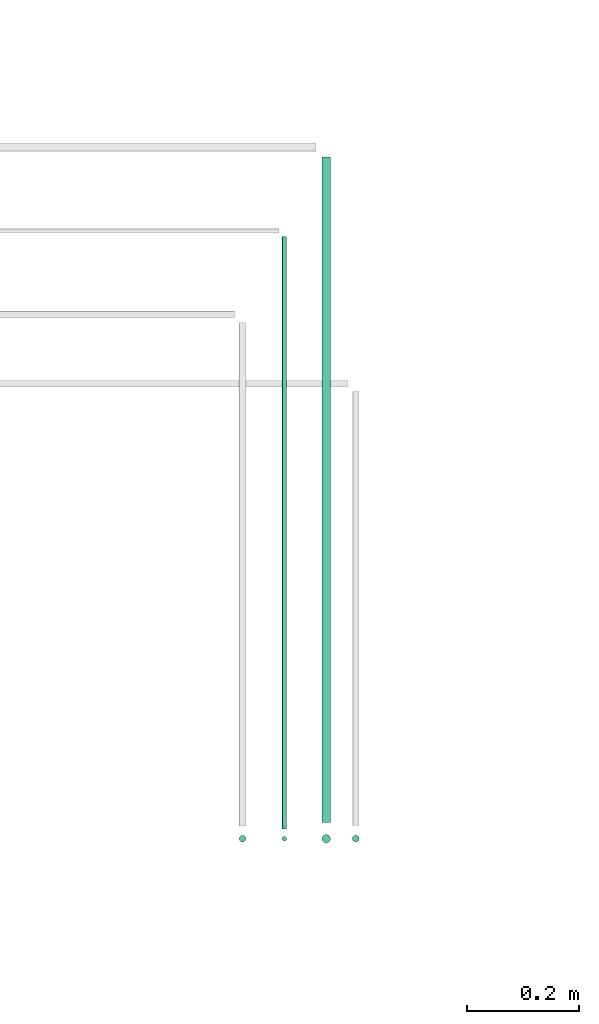
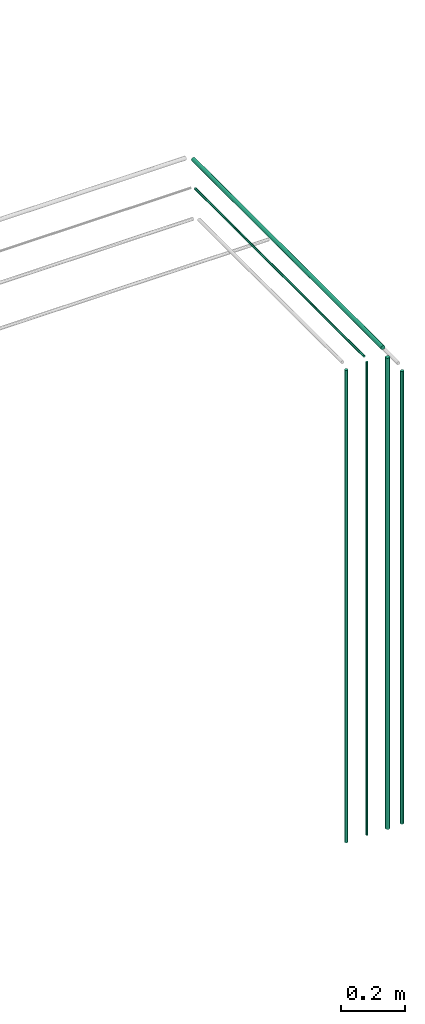
# One storey, part 23 of 65: 6 flow segments.
"""IFC2X3 building model written with IfcOpenShell, lengths in millimetres."""

from ifc_helpers import new_model, entity, si_unit, converted_unit, derived_unit, direction, frame, frame_2d, origin, origin_2d_with_axis, place, context, subcontext, project, spatial, circle, extrude, type_object, element, save


model = new_model("IFC2X3")

# Units and contexts
model_context = context("Model", 3, precision=0.01, world=origin(), true_north=direction((6.12303176911189e-17, 1.0)))
body_context = subcontext(model_context, "Body", "Model", "MODEL_VIEW")
ifc_project = project(units=[si_unit("LENGTHUNIT", "METRE", prefix="MILLI"), si_unit("AREAUNIT", "SQUARE_METRE"), si_unit("VOLUMEUNIT", "CUBIC_METRE"), converted_unit("PLANEANGLEUNIT", "DEGREE", entity("IfcRatioMeasure", 0.0174532925199433), si_unit("PLANEANGLEUNIT", "RADIAN"), dimensions=[0, 0, 0, 0, 0, 0, 0]), si_unit("MASSUNIT", "GRAM", prefix="KILO"), derived_unit("MASSDENSITYUNIT", [(si_unit("MASSUNIT", "GRAM", prefix="KILO"), 1), (si_unit("LENGTHUNIT", "METRE"), -3)]), derived_unit("MOMENTOFINERTIAUNIT", [(si_unit("LENGTHUNIT", "METRE"), 4)]), si_unit("TIMEUNIT", "SECOND"), si_unit("FREQUENCYUNIT", "HERTZ"), si_unit("THERMODYNAMICTEMPERATUREUNIT", "DEGREE_CELSIUS"), derived_unit("THERMALTRANSMITTANCEUNIT", [(si_unit("MASSUNIT", "GRAM", prefix="KILO"), 1), (si_unit("THERMODYNAMICTEMPERATUREUNIT", "KELVIN"), -1), (si_unit("TIMEUNIT", "SECOND"), -3)]), derived_unit("VOLUMETRICFLOWRATEUNIT", [(si_unit("LENGTHUNIT", "METRE"), 3), (si_unit("TIMEUNIT", "SECOND"), -1)]), derived_unit("MASSFLOWRATEUNIT", [(si_unit("MASSUNIT", "GRAM", prefix="KILO"), 1), (si_unit("TIMEUNIT", "SECOND"), -1)]), derived_unit("ROTATIONALFREQUENCYUNIT", [(si_unit("TIMEUNIT", "SECOND"), -1)]), si_unit("ELECTRICCURRENTUNIT", "AMPERE"), si_unit("ELECTRICVOLTAGEUNIT", "VOLT"), si_unit("POWERUNIT", "WATT"), si_unit("FORCEUNIT", "NEWTON", prefix="KILO"), si_unit("ILLUMINANCEUNIT", "LUX"), si_unit("LUMINOUSFLUXUNIT", "LUMEN"), si_unit("LUMINOUSINTENSITYUNIT", "CANDELA"), derived_unit("USERDEFINED", [(si_unit("MASSUNIT", "GRAM", prefix="KILO"), -1), (si_unit("LENGTHUNIT", "METRE"), -2), (si_unit("TIMEUNIT", "SECOND"), 3), (si_unit("LUMINOUSFLUXUNIT", "LUMEN"), 1)]), derived_unit("LINEARVELOCITYUNIT", [(si_unit("LENGTHUNIT", "METRE"), 1), (si_unit("TIMEUNIT", "SECOND"), -1)]), si_unit("PRESSUREUNIT", "PASCAL"), derived_unit("USERDEFINED", [(si_unit("LENGTHUNIT", "METRE"), -2), (si_unit("MASSUNIT", "GRAM", prefix="KILO"), 1), (si_unit("TIMEUNIT", "SECOND"), -2)]), derived_unit("LINEARFORCEUNIT", [(si_unit("MASSUNIT", "GRAM", prefix="KILO"), 1), (si_unit("LENGTHUNIT", "METRE"), 1), (si_unit("TIMEUNIT", "SECOND"), -2), (si_unit("LENGTHUNIT", "METRE"), -1)]), derived_unit("PLANARFORCEUNIT", [(si_unit("MASSUNIT", "GRAM", prefix="KILO"), 1), (si_unit("LENGTHUNIT", "METRE"), 1), (si_unit("TIMEUNIT", "SECOND"), -2), (si_unit("LENGTHUNIT", "METRE"), -2)])], contexts=[model_context])

# Site, building, storey
site_placement = place(None, frame((0.0, -0.00077364408347762, 0.0)))
site = spatial("IfcSite", under=ifc_project, at=site_placement, CompositionType="ELEMENT")
building_placement = place(site_placement, origin())
building = spatial("IfcBuilding", under=site, at=building_placement, CompositionType="ELEMENT")
storey_placement = place(building_placement, frame((0.0, 0.0, 19800.0)))
storey = spatial("IfcBuildingStorey", under=building, at=storey_placement, CompositionType="ELEMENT", Elevation=19800.0)

# Flow segments
pipe_segment_type = type_object("IfcPipeSegmentType", PredefinedType="NOTDEFINED")
flow_segment_1_placement = place(storey_placement, frame((72120.2991206651, 2954.56654236312, 3215.90472776409)))
element("IfcFlowSegment", 1, at=flow_segment_1_placement, inside=storey, type_object=pipe_segment_type, context=body_context, shape_type="SweptSolid", body=[
    extrude(circle(Radius=7.5, at=origin_2d_with_axis()), frame((9.09527223592286, 0.0, 9.09527223591419), z_axis=(0.0, 1.0, 0.0), x_axis=(-1.0, 0.0, 0.0)), (0.0, 0.0, 1.0), 1191.84472027818),
])
flow_segment_2_placement = place(storey_placement, frame((72048.7991206651, 2942.56654236312, 3219.40472776408)))
element("IfcFlowSegment", 2, at=flow_segment_2_placement, inside=storey, type_object=pipe_segment_type, context=body_context, shape_type="SweptSolid", body=[
    extrude(circle(Radius=4.0, at=origin_2d_with_axis()), frame((5.59527223591499, 0.0, 5.59527223591499), z_axis=(0.0, 1.0, 0.0), x_axis=(-1.0, 0.0, 0.0)), (0.0, 0.0, 1.0), 1061.84472027819),
])
flow_segment_3_placement = place(storey_placement, frame((71971.7991206651, 2917.97127012716, 1400.0)))
element("IfcFlowSegment", 3, at=flow_segment_3_placement, inside=storey, type_object=pipe_segment_type, context=body_context, shape_type="SweptSolid", body=[
    extrude(circle(Radius=6.0, at=origin_2d_with_axis()), frame((7.59527223591454, 7.59527223591616, 0.0), z_axis=(0.0, 0.0, 1.0), x_axis=(-1.0, 0.0, 0.0)), (0.0, 0.0, 1.0), 1811.0),
])
flow_segment_4_placement = place(storey_placement, frame((72048.7991206651, 2919.97127012716, 1400.0)))
element("IfcFlowSegment", 4, at=flow_segment_4_placement, inside=storey, type_object=pipe_segment_type, context=body_context, shape_type="SweptSolid", body=[
    extrude(circle(Radius=4.0, at=origin_2d_with_axis()), frame((5.59527223591499, 5.59527223591607, 0.0), z_axis=(0.0, 0.0, 1.0), x_axis=(-1.0, 0.0, 0.0)), (0.0, 0.0, 1.0), 1815.0),
])
flow_segment_5_placement = place(storey_placement, frame((72120.2991206651, 2916.47127012716, 1400.0)))
element("IfcFlowSegment", 5, at=flow_segment_5_placement, inside=storey, type_object=pipe_segment_type, context=body_context, shape_type="SweptSolid", body=[
    extrude(circle(Radius=7.5, at=frame_2d((-8.66293703438714e-12, 0.0), x_axis=(1.0, 0.0))), frame((9.09527223590553, 9.09527223591582, 0.0), z_axis=(0.0, 0.0, 1.0), x_axis=(-1.0, 0.0, 0.0)), (0.0, 0.0, 1.0), 1807.0),
])
flow_segment_6_placement = place(storey_placement, frame((72174.5546120835, 2918.2380638167, 1400.0)))
element("IfcFlowSegment", 6, at=flow_segment_6_placement, inside=storey, type_object=pipe_segment_type, context=body_context, shape_type="SweptSolid", body=[
    extrude(circle(Radius=6.0, at=origin_2d_with_axis()), frame((7.59527223591454, 7.59527223591616, 0.0), z_axis=(0.0, 0.0, 1.0), x_axis=(-1.0, 0.0, 0.0)), (0.0, 0.0, 1.0), 1736.0),
])

save(model, "model.ifc")
